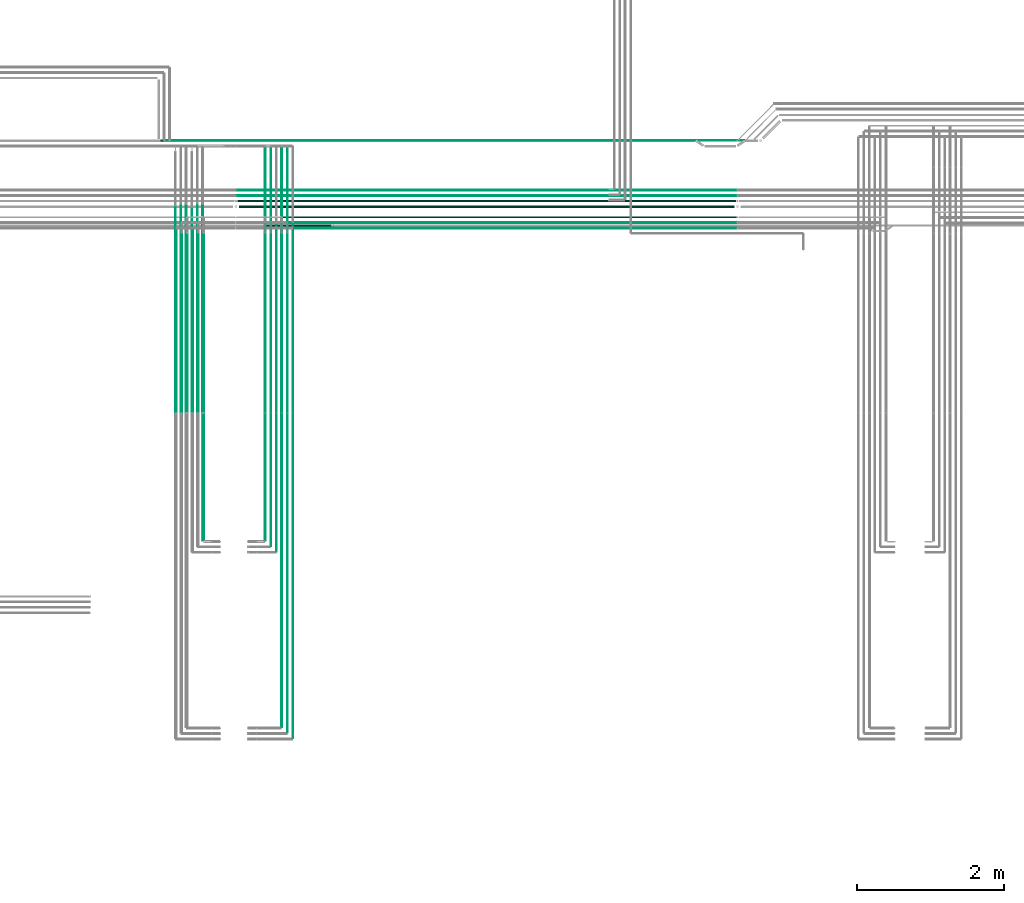
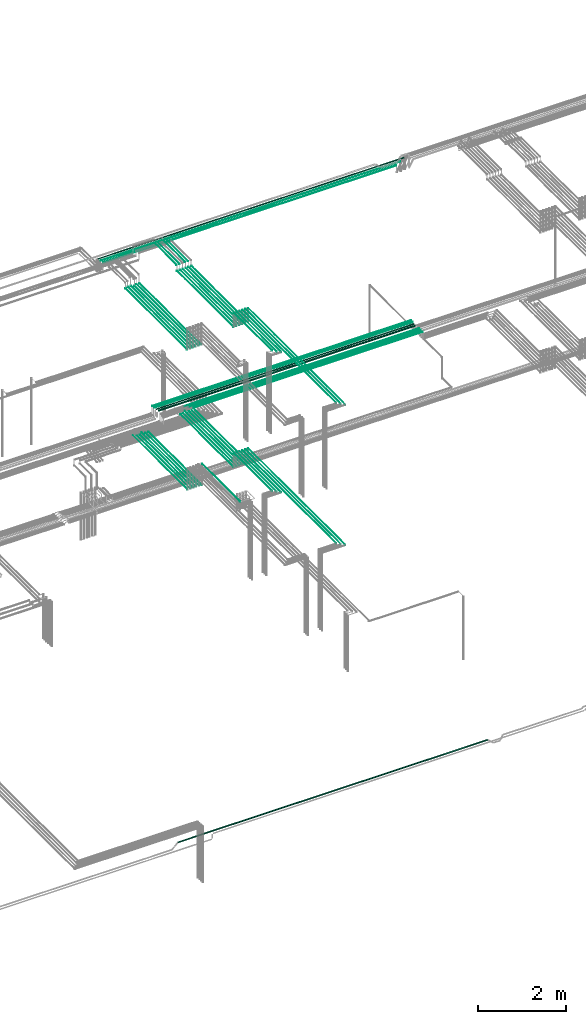
# One storey, part 19 of 331: 52 flow segments.
"""IFC2X3 building model written with IfcOpenShell, lengths in millimetres."""

from ifc_helpers import new_model, entity, si_unit, converted_unit, derived_unit, direction, frame, frame_2d, origin, origin_2d_with_axis, place, context, subcontext, project, spatial, circle, extrude, type_object, element, save


model = new_model("IFC2X3")

# Units and contexts
model_context = context("Model", 3, precision=0.01, world=origin(), true_north=direction((6.12303176911189e-17, 1.0)))
body_context = subcontext(model_context, "Body", "Model", "MODEL_VIEW")
ifc_project = project(units=[si_unit("LENGTHUNIT", "METRE", prefix="MILLI"), si_unit("AREAUNIT", "SQUARE_METRE"), si_unit("VOLUMEUNIT", "CUBIC_METRE"), converted_unit("PLANEANGLEUNIT", "DEGREE", entity("IfcRatioMeasure", 0.0174532925199433), si_unit("PLANEANGLEUNIT", "RADIAN"), dimensions=[0, 0, 0, 0, 0, 0, 0]), si_unit("MASSUNIT", "GRAM", prefix="KILO"), derived_unit("MASSDENSITYUNIT", [(si_unit("MASSUNIT", "GRAM", prefix="KILO"), 1), (si_unit("LENGTHUNIT", "METRE"), -3)]), derived_unit("MOMENTOFINERTIAUNIT", [(si_unit("LENGTHUNIT", "METRE"), 4)]), si_unit("TIMEUNIT", "SECOND"), si_unit("FREQUENCYUNIT", "HERTZ"), si_unit("THERMODYNAMICTEMPERATUREUNIT", "DEGREE_CELSIUS"), derived_unit("THERMALTRANSMITTANCEUNIT", [(si_unit("MASSUNIT", "GRAM", prefix="KILO"), 1), (si_unit("THERMODYNAMICTEMPERATUREUNIT", "KELVIN"), -1), (si_unit("TIMEUNIT", "SECOND"), -3)]), derived_unit("VOLUMETRICFLOWRATEUNIT", [(si_unit("LENGTHUNIT", "METRE"), 3), (si_unit("TIMEUNIT", "SECOND"), -1)]), derived_unit("MASSFLOWRATEUNIT", [(si_unit("MASSUNIT", "GRAM", prefix="KILO"), 1), (si_unit("TIMEUNIT", "SECOND"), -1)]), derived_unit("ROTATIONALFREQUENCYUNIT", [(si_unit("TIMEUNIT", "SECOND"), -1)]), si_unit("ELECTRICCURRENTUNIT", "AMPERE"), si_unit("ELECTRICVOLTAGEUNIT", "VOLT"), si_unit("POWERUNIT", "WATT"), si_unit("FORCEUNIT", "NEWTON", prefix="KILO"), si_unit("ILLUMINANCEUNIT", "LUX"), si_unit("LUMINOUSFLUXUNIT", "LUMEN"), si_unit("LUMINOUSINTENSITYUNIT", "CANDELA"), derived_unit("USERDEFINED", [(si_unit("MASSUNIT", "GRAM", prefix="KILO"), -1), (si_unit("LENGTHUNIT", "METRE"), -2), (si_unit("TIMEUNIT", "SECOND"), 3), (si_unit("LUMINOUSFLUXUNIT", "LUMEN"), 1)]), derived_unit("LINEARVELOCITYUNIT", [(si_unit("LENGTHUNIT", "METRE"), 1), (si_unit("TIMEUNIT", "SECOND"), -1)]), si_unit("PRESSUREUNIT", "PASCAL"), derived_unit("USERDEFINED", [(si_unit("LENGTHUNIT", "METRE"), -2), (si_unit("MASSUNIT", "GRAM", prefix="KILO"), 1), (si_unit("TIMEUNIT", "SECOND"), -2)]), derived_unit("LINEARFORCEUNIT", [(si_unit("MASSUNIT", "GRAM", prefix="KILO"), 1), (si_unit("LENGTHUNIT", "METRE"), 1), (si_unit("TIMEUNIT", "SECOND"), -2), (si_unit("LENGTHUNIT", "METRE"), -1)]), derived_unit("PLANARFORCEUNIT", [(si_unit("MASSUNIT", "GRAM", prefix="KILO"), 1), (si_unit("LENGTHUNIT", "METRE"), 1), (si_unit("TIMEUNIT", "SECOND"), -2), (si_unit("LENGTHUNIT", "METRE"), -2)])], contexts=[model_context])

# Site, building, storey
site_placement = place(None, frame((0.0, -0.00077364408347762, 0.0)))
site = spatial("IfcSite", under=ifc_project, at=site_placement, CompositionType="ELEMENT")
building_placement = place(site_placement, origin())
building = spatial("IfcBuilding", under=site, at=building_placement, CompositionType="ELEMENT")
storey_placement = place(building_placement, origin())
storey = spatial("IfcBuildingStorey", under=building, at=storey_placement, CompositionType="ELEMENT", Elevation=0.0)

# Flow segments
pipe_segment_type = type_object("IfcPipeSegmentType", PredefinedType="NOTDEFINED")
for number, where in (
    (1, (35540.5130615671, 5653.62056382741, 14744.4047277641)),
    (2, (35765.5130615671, 5653.62056382741, 14744.4047277641)),
):
    element("IfcFlowSegment", number, at=place(storey_placement, frame(where)), inside=storey, type_object=pipe_segment_type, context=body_context, shape_type="SweptSolid", body=[
        extrude(circle(Radius=4.0, at=origin_2d_with_axis()), frame((5.59527223591499, 0.0, 5.59527223591499), z_axis=(0.0, 1.0, 0.0), x_axis=(-1.0, 0.0, 0.0)), (0.0, 0.0, 1.0), 2489.38938002189),
    ])
flow_segment_1_placement = place(storey_placement, frame((35465.5130615671, 5653.62056382741, 14744.4047277641)))
element("IfcFlowSegment", 3, at=flow_segment_1_placement, inside=storey, type_object=pipe_segment_type, context=body_context, shape_type="SweptSolid", body=[
    extrude(circle(Radius=4.0, at=origin_2d_with_axis()), frame((5.59527223591499, 0.0, 5.59527223591499), z_axis=(0.0, 1.0, 0.0), x_axis=(-1.0, 0.0, 0.0)), (0.0, 0.0, 1.0), 2426.52868594872),
])
flow_segment_2_placement = place(storey_placement, frame((35690.5130615671, 5653.62056382741, 14744.4047277641)))
element("IfcFlowSegment", 4, at=flow_segment_2_placement, inside=storey, type_object=pipe_segment_type, context=body_context, shape_type="SweptSolid", body=[
    extrude(circle(Radius=4.0, at=origin_2d_with_axis()), frame((5.59527223591499, 0.0, 5.59527223591499), z_axis=(0.0, 1.0, 0.0), x_axis=(-1.0, 0.0, 0.0)), (0.0, 0.0, 1.0), 2426.52868594873),
])
flow_segment_3_placement = place(storey_placement, frame((35388.5130615671, 5657.62056382741, 14742.4047277641)))
element("IfcFlowSegment", 5, at=flow_segment_3_placement, inside=storey, type_object=pipe_segment_type, context=body_context, shape_type="SweptSolid", body=[
    extrude(circle(Radius=6.0, at=frame_2d((8.66293703438714e-12, 0.0), x_axis=(1.0, 0.0))), frame((7.5952722359232, 0.0, 7.5952722359167), z_axis=(0.0, 1.0, 0.0), x_axis=(-1.0, 0.0, 0.0)), (0.0, 0.0, 1.0), 2418.52868594873),
])
flow_segment_4_placement = place(storey_placement, frame((35613.5130615671, 5657.62056382741, 14742.4047277641)))
element("IfcFlowSegment", 6, at=flow_segment_4_placement, inside=storey, type_object=pipe_segment_type, context=body_context, shape_type="SweptSolid", body=[
    extrude(circle(Radius=6.0, at=origin_2d_with_axis()), frame((7.59527223591454, 0.0, 7.5952722359167), z_axis=(0.0, 1.0, 0.0), x_axis=(-1.0, 0.0, 0.0)), (0.0, 0.0, 1.0), 2418.52868594872),
])
flow_segment_5_placement = place(storey_placement, frame((35613.5130615671, 1365.48876707914, 15142.4047277641)))
element("IfcFlowSegment", 7, at=flow_segment_5_placement, inside=storey, type_object=pipe_segment_type, context=body_context, shape_type="SweptSolid", body=[
    extrude(circle(Radius=6.0, at=frame_2d((0.0, 2.16573425859679e-12), x_axis=(1.0, 0.0))), frame((7.59527223591454, 0.0, 7.59527223591887), z_axis=(0.0, 1.0, 0.0), x_axis=(1.0, 0.0, 0.0)), (0.0, 0.0, 1.0), 4264.13179674827),
])
flow_segment_6_placement = place(storey_placement, frame((35388.5130615671, 3905.48876707929, 15142.4047277641)))
element("IfcFlowSegment", 8, at=flow_segment_6_placement, inside=storey, type_object=pipe_segment_type, context=body_context, shape_type="SweptSolid", body=[
    extrude(circle(Radius=6.0, at=frame_2d((0.0, 2.16573425859679e-12), x_axis=(1.0, 0.0))), frame((7.59527223591454, 0.0, 7.59527223591887), z_axis=(0.0, 1.0, 0.0), x_axis=(1.0, 0.0, 0.0)), (0.0, 0.0, 1.0), 1724.13179674812),
])
flow_segment_7_placement = place(storey_placement, frame((35690.5130615671, 1286.48876707975, 15144.4047277641)))
element("IfcFlowSegment", 9, at=flow_segment_7_placement, inside=storey, type_object=pipe_segment_type, context=body_context, shape_type="SweptSolid", body=[
    extrude(circle(Radius=4.0, at=origin_2d_with_axis()), frame((5.59527223591499, 0.0, 5.59527223591499), z_axis=(0.0, 1.0, 0.0), x_axis=(1.0, 0.0, 0.0)), (0.0, 0.0, 1.0), 4347.13179674766),
])
flow_segment_8_placement = place(storey_placement, frame((35765.5130615671, 1211.4887670793, 15144.4047277641)))
element("IfcFlowSegment", 10, at=flow_segment_8_placement, inside=storey, type_object=pipe_segment_type, context=body_context, shape_type="SweptSolid", body=[
    extrude(circle(Radius=4.0, at=origin_2d_with_axis()), frame((5.59527223591499, 0.0, 5.59527223591499), z_axis=(0.0, 1.0, 0.0), x_axis=(1.0, 0.0, 0.0)), (0.0, 0.0, 1.0), 4422.13179674811),
])
flow_segment_9_placement = place(storey_placement, frame((35465.5130615671, 3826.48876707975, 15144.4047277641)))
element("IfcFlowSegment", 11, at=flow_segment_9_placement, inside=storey, type_object=pipe_segment_type, context=body_context, shape_type="SweptSolid", body=[
    extrude(circle(Radius=4.0, at=origin_2d_with_axis()), frame((5.59527223591499, 0.0, 5.59527223591499), z_axis=(0.0, 1.0, 0.0), x_axis=(1.0, 0.0, 0.0)), (0.0, 0.0, 1.0), 1807.13179674766),
])
flow_segment_10_placement = place(storey_placement, frame((35540.5130615671, 3751.48876707903, 15144.4047277641)))
element("IfcFlowSegment", 12, at=flow_segment_10_placement, inside=storey, type_object=pipe_segment_type, context=body_context, shape_type="SweptSolid", body=[
    extrude(circle(Radius=4.0, at=origin_2d_with_axis()), frame((5.59527223591499, 0.0, 5.59527223591499), z_axis=(0.0, 1.0, 0.0), x_axis=(1.0, 0.0, 0.0)), (0.0, 0.0, 1.0), 1882.13179674838),
])
flow_segment_11_placement = place(storey_placement, frame((34403.5132627125, 5653.62056382741, 14544.4047277641)))
element("IfcFlowSegment", 13, at=flow_segment_11_placement, inside=storey, type_object=pipe_segment_type, context=body_context, shape_type="SweptSolid", body=[
    extrude(circle(Radius=4.0, at=frame_2d((-1.29944055515807e-11, 0.0), x_axis=(1.0, 0.0))), frame((5.59527223592365, 0.0, 5.59527223591499), z_axis=(0.0, 1.0, 0.0), x_axis=(-1.0, 0.0, 0.0)), (0.0, 0.0, 1.0), 2489.38938002187),
])
flow_segment_12_placement = place(storey_placement, frame((34178.5132627125, 5653.62056382741, 14544.4047277641)))
element("IfcFlowSegment", 14, at=flow_segment_12_placement, inside=storey, type_object=pipe_segment_type, context=body_context, shape_type="SweptSolid", body=[
    extrude(circle(Radius=4.0, at=frame_2d((-4.33146851719357e-12, 0.0), x_axis=(1.0, 0.0))), frame((5.59527223592365, 0.0, 5.59527223591499), z_axis=(0.0, 1.0, 0.0), x_axis=(-1.0, 0.0, 0.0)), (0.0, 0.0, 1.0), 2489.38938002186),
])
flow_segment_13_placement = place(storey_placement, frame((34478.5132627125, 5653.62056382741, 14544.4047277641)))
element("IfcFlowSegment", 15, at=flow_segment_13_placement, inside=storey, type_object=pipe_segment_type, context=body_context, shape_type="SweptSolid", body=[
    extrude(circle(Radius=4.0, at=origin_2d_with_axis()), frame((5.59527223591499, 0.0, 5.59527223591499), z_axis=(0.0, 1.0, 0.0), x_axis=(-1.0, 0.0, 0.0)), (0.0, 0.0, 1.0), 2426.52868594871),
])
flow_segment_14_placement = place(storey_placement, frame((34253.5132627125, 5653.62056382741, 14544.4047277641)))
element("IfcFlowSegment", 16, at=flow_segment_14_placement, inside=storey, type_object=pipe_segment_type, context=body_context, shape_type="SweptSolid", body=[
    extrude(circle(Radius=4.0, at=origin_2d_with_axis()), frame((5.59527223591499, 0.0, 5.59527223591499), z_axis=(0.0, 1.0, 0.0), x_axis=(-1.0, 0.0, 0.0)), (0.0, 0.0, 1.0), 2426.52868594872),
])
flow_segment_15_placement = place(storey_placement, frame((34551.5132627125, 5657.62056382741, 14542.4047277641)))
element("IfcFlowSegment", 17, at=flow_segment_15_placement, inside=storey, type_object=pipe_segment_type, context=body_context, shape_type="SweptSolid", body=[
    extrude(circle(Radius=6.0, at=frame_2d((-8.66293703438714e-12, -2.16573425859679e-12), x_axis=(1.0, 0.0))), frame((7.5952722359232, 0.0, 7.59527223591887), z_axis=(0.0, 1.0, 0.0), x_axis=(-1.0, 0.0, 0.0)), (0.0, 0.0, 1.0), 2418.52868594873),
])
flow_segment_16_placement = place(storey_placement, frame((34326.5132627125, 5657.62056382741, 14542.4047277641)))
element("IfcFlowSegment", 18, at=flow_segment_16_placement, inside=storey, type_object=pipe_segment_type, context=body_context, shape_type="SweptSolid", body=[
    extrude(circle(Radius=6.0, at=origin_2d_with_axis()), frame((7.59527223591454, 0.0, 7.5952722359167), z_axis=(0.0, 1.0, 0.0), x_axis=(-1.0, 0.0, 0.0)), (0.0, 0.0, 1.0), 2418.52868594872),
])
flow_segment_17_placement = place(storey_placement, frame((34551.5132627125, 3905.48876707931, 15142.4047277641)))
element("IfcFlowSegment", 19, at=flow_segment_17_placement, inside=storey, type_object=pipe_segment_type, context=body_context, shape_type="SweptSolid", body=[
    extrude(circle(Radius=6.0, at=frame_2d((0.0, 2.16573425859679e-12), x_axis=(1.0, 0.0))), frame((7.59527223591454, 0.0, 7.59527223591887), z_axis=(0.0, 1.0, 0.0), x_axis=(1.0, 0.0, 0.0)), (0.0, 0.0, 1.0), 1724.1317967481),
])
flow_segment_18_placement = place(storey_placement, frame((35778.108333803, 8148.41467161336, 14742.4047277641)))
element("IfcFlowSegment", 20, at=flow_segment_18_placement, inside=storey, type_object=pipe_segment_type, context=body_context, shape_type="SweptSolid", body=[
    extrude(circle(Radius=6.0, at=frame_2d((0.0, 2.16573425859679e-12), x_axis=(1.0, 0.0))), frame((0.0, 7.59527223593403, 7.59527223591887), z_axis=(1.0, 0.0, 0.0), x_axis=(0.0, -1.0, 0.0)), (0.0, 0.0, 1.0), 6029.07227010458),
])
flow_segment_19_placement = place(storey_placement, frame((35703.1083377242, 8223.41467161339, 14742.4047277641)))
element("IfcFlowSegment", 21, at=flow_segment_19_placement, inside=storey, type_object=pipe_segment_type, context=body_context, shape_type="SweptSolid", body=[
    extrude(circle(Radius=6.0, at=frame_2d((-1.08286712929839e-12, -2.16573425859679e-12), x_axis=(1.0, 0.0))), frame((0.0, 7.59527223593403, 7.59527223591454), z_axis=(1.0, 0.0, 0.0), x_axis=(0.0, -1.0, 0.0)), (0.0, 0.0, 1.0), 6104.07226741911),
])
flow_segment_20_placement = place(storey_placement, frame((35629.1083191253, 8296.91467161339, 14740.9047401324)))
element("IfcFlowSegment", 22, at=flow_segment_20_placement, inside=storey, type_object=pipe_segment_type, context=body_context, shape_type="SweptSolid", body=[
    extrude(circle(Radius=7.5, at=origin_2d_with_axis()), frame((0.0, 9.09527223593585, 9.09527223591636), z_axis=(1.0, 0.0, 0.0), x_axis=(0.0, -1.0, 0.0)), (0.0, 0.0, 1.0), 6174.07228788098),
])
flow_segment_21_placement = place(storey_placement, frame((35010.080551462, 8668.02529159146, 14742.4047277641)))
element("IfcFlowSegment", 23, at=flow_segment_21_placement, inside=storey, type_object=pipe_segment_type, context=body_context, shape_type="SweptSolid", body=[
    extrude(circle(Radius=6.0, at=frame_2d((-8.66293703438714e-12, 2.16573425859679e-12), x_axis=(1.0, 0.0))), frame((0.0, 7.59527223592428, 7.59527223591454), z_axis=(1.0, 0.0, 0.0), x_axis=(0.0, 1.0, 0.0)), (0.0, 0.0, 1.0), 6797.10005244561),
])
flow_segment_22_placement = place(storey_placement, frame((35010.080551462, 8593.02529159146, 14742.4047277641)))
element("IfcFlowSegment", 24, at=flow_segment_22_placement, inside=storey, type_object=pipe_segment_type, context=body_context, shape_type="SweptSolid", body=[
    extrude(circle(Radius=6.0, at=frame_2d((-8.66293703438714e-12, 0.0), x_axis=(1.0, 0.0))), frame((0.0, 7.59527223592428, 7.5952722359167), z_axis=(1.0, 0.0, 0.0), x_axis=(0.0, 1.0, 0.0)), (0.0, 0.0, 1.0), 6797.1000524456),
])
flow_segment_23_placement = place(storey_placement, frame((35020.080551462, 8513.02529159144, 14737.4047277641)))
element("IfcFlowSegment", 25, at=flow_segment_23_placement, inside=storey, type_object=pipe_segment_type, context=body_context, shape_type="SweptSolid", body=[
    extrude(circle(Radius=11.0, at=frame_2d((0.0, -2.16573425859679e-12), x_axis=(1.0, 0.0))), frame((0.0, 12.5952722359329, 12.5952722359134), z_axis=(1.0, 0.0, 0.0), x_axis=(0.0, -1.0, 0.0)), (0.0, 0.0, 1.0), 6777.1000524456),
])
flow_segment_24_placement = place(storey_placement, frame((35036.080551462, 8431.52529159142, 14730.9047277638)))
element("IfcFlowSegment", 26, at=flow_segment_24_placement, inside=storey, type_object=pipe_segment_type, context=body_context, shape_type="SweptSolid", body=[
    extrude(circle(Radius=17.5, at=origin_2d_with_axis()), frame((0.0, 19.0952722359336, 19.0952722359163), z_axis=(1.0, 0.0, 0.0), x_axis=(0.0, -1.0, 0.0)), (0.0, 0.0, 1.0), 6745.10005244563),
])
flow_segment_25_placement = place(storey_placement, frame((34110.0511495452, 9342.40472776411, 18642.4047277641)))
element("IfcFlowSegment", 27, at=flow_segment_25_placement, inside=storey, type_object=pipe_segment_type, context=body_context, shape_type="SweptSolid", body=[
    extrude(circle(Radius=6.0, at=frame_2d((3.35688810082502e-11, 0.0), x_axis=(1.0, 0.0))), frame((0.0, 7.59527223594919, 7.5952722359167), z_axis=(1.0, 0.0, 0.0), x_axis=(0.0, 1.0, 0.0)), (0.0, 0.0, 1.0), 7696.04795075196),
])
flow_segment_26_placement = place(storey_placement, frame((34390.4558773093, 5653.62056382734, 18444.4047277641)))
element("IfcFlowSegment", 28, at=flow_segment_26_placement, inside=storey, type_object=pipe_segment_type, context=body_context, shape_type="SweptSolid", body=[
    extrude(circle(Radius=4.0, at=frame_2d((-4.33146851719357e-12, 0.0), x_axis=(1.0, 0.0))), frame((5.59527223591499, 0.0, 5.59527223591499), z_axis=(0.0, 1.0, 0.0), x_axis=(-1.0, 0.0, 0.0)), (0.0, 0.0, 1.0), 2777.21564201884),
])
flow_segment_27_placement = place(storey_placement, frame((34165.4558773093, 5653.62056382734, 18444.4047277641)))
element("IfcFlowSegment", 29, at=flow_segment_27_placement, inside=storey, type_object=pipe_segment_type, context=body_context, shape_type="SweptSolid", body=[
    extrude(circle(Radius=4.0, at=origin_2d_with_axis()), frame((5.59527223591499, 0.0, 5.59527223591499), z_axis=(0.0, 1.0, 0.0), x_axis=(1.0, 0.0, 0.0)), (0.0, 0.0, 1.0), 2795.00000000001),
])
for number, where in (
    (30, (34465.4558773093, 5653.62056382735, 18444.4047277641)),
    (31, (34240.4558773093, 5653.62056382735, 18444.4047277641)),
):
    element("IfcFlowSegment", number, at=place(storey_placement, frame(where)), inside=storey, type_object=pipe_segment_type, context=body_context, shape_type="SweptSolid", body=[
        extrude(circle(Radius=4.0, at=origin_2d_with_axis()), frame((5.59527223591499, 0.0, 5.59527223591499), z_axis=(0.0, 1.0, 0.0), x_axis=(-1.0, 0.0, 0.0)), (0.0, 0.0, 1.0), 2821.19017065502),
    ])
flow_segment_28_placement = place(storey_placement, frame((34538.4558773093, 5657.62056382736, 18442.4047277641)))
element("IfcFlowSegment", 32, at=flow_segment_28_placement, inside=storey, type_object=pipe_segment_type, context=body_context, shape_type="SweptSolid", body=[
    extrude(circle(Radius=6.0, at=origin_2d_with_axis()), frame((7.59527223591454, 0.0, 7.5952722359167), z_axis=(0.0, 1.0, 0.0), x_axis=(-1.0, 0.0, 0.0)), (0.0, 0.0, 1.0), 2813.190170655),
])
flow_segment_29_placement = place(storey_placement, frame((34313.4558773093, 5657.62056382735, 18442.4047277641)))
element("IfcFlowSegment", 33, at=flow_segment_29_placement, inside=storey, type_object=pipe_segment_type, context=body_context, shape_type="SweptSolid", body=[
    extrude(circle(Radius=6.0, at=origin_2d_with_axis()), frame((7.59527223591454, 0.0, 7.5952722359167), z_axis=(0.0, 1.0, 0.0), x_axis=(-1.0, 0.0, 0.0)), (0.0, 0.0, 1.0), 2813.19017065502),
])
for number, where in (
    (34, (35540.7427281404, 5653.62056382734, 18644.4047277641)),
    (35, (35765.7427281405, 5653.62056382734, 18644.4047277641)),
):
    element("IfcFlowSegment", number, at=place(storey_placement, frame(where)), inside=storey, type_object=pipe_segment_type, context=body_context, shape_type="SweptSolid", body=[
        extrude(circle(Radius=4.0, at=origin_2d_with_axis()), frame((5.59527223591499, 0.0, 5.59527223591499), z_axis=(0.0, 1.0, 0.0), x_axis=(-1.0, 0.0, 0.0)), (0.0, 0.0, 1.0), 2571.19017065503),
    ])
flow_segment_30_placement = place(storey_placement, frame((35465.7427281404, 8244.81073448236, 18794.4047277641)))
element("IfcFlowSegment", 36, at=flow_segment_30_placement, inside=storey, type_object=pipe_segment_type, context=body_context, shape_type="SweptSolid", body=[
    extrude(circle(Radius=4.0, at=frame_2d((8.66293703438714e-12, 0.0), x_axis=(1.0, 0.0))), frame((5.59527223592365, 0.0, 5.59527223591499), z_axis=(0.0, 1.0, 0.0), x_axis=(-1.0, 0.0, 0.0)), (0.0, 0.0, 1.0), 1020.18926551794),
])
flow_segment_31_placement = place(storey_placement, frame((35465.7427281405, 5653.62056382735, 18644.4047277641)))
element("IfcFlowSegment", 37, at=flow_segment_31_placement, inside=storey, type_object=pipe_segment_type, context=body_context, shape_type="SweptSolid", body=[
    extrude(circle(Radius=4.0, at=origin_2d_with_axis()), frame((5.59527223591499, 0.0, 5.59527223591499), z_axis=(0.0, 1.0, 0.0), x_axis=(-1.0, 0.0, 0.0)), (0.0, 0.0, 1.0), 2571.19017065501),
])
flow_segment_32_placement = place(storey_placement, frame((35690.7427281404, 8244.81073448235, 18794.4047277641)))
element("IfcFlowSegment", 38, at=flow_segment_32_placement, inside=storey, type_object=pipe_segment_type, context=body_context, shape_type="SweptSolid", body=[
    extrude(circle(Radius=4.0, at=frame_2d((8.66293703438714e-12, 0.0), x_axis=(1.0, 0.0))), frame((5.59527223592365, 0.0, 5.59527223591499), z_axis=(0.0, 1.0, 0.0), x_axis=(-1.0, 0.0, 0.0)), (0.0, 0.0, 1.0), 1020.18926551795),
])
flow_segment_33_placement = place(storey_placement, frame((35690.7427281405, 5653.62056382734, 18644.4047277641)))
element("IfcFlowSegment", 39, at=flow_segment_33_placement, inside=storey, type_object=pipe_segment_type, context=body_context, shape_type="SweptSolid", body=[
    extrude(circle(Radius=4.0, at=origin_2d_with_axis()), frame((5.59527223591499, 0.0, 5.59527223591499), z_axis=(0.0, 1.0, 0.0), x_axis=(-1.0, 0.0, 0.0)), (0.0, 0.0, 1.0), 2571.19017065502),
])
flow_segment_34_placement = place(storey_placement, frame((35388.7427281404, 8248.81073448236, 18792.4047277641)))
element("IfcFlowSegment", 40, at=flow_segment_34_placement, inside=storey, type_object=pipe_segment_type, context=body_context, shape_type="SweptSolid", body=[
    extrude(circle(Radius=6.0, at=frame_2d((1.29944055515807e-11, 0.0), x_axis=(1.0, 0.0))), frame((7.59527223592753, 0.0, 7.5952722359167), z_axis=(0.0, 1.0, 0.0), x_axis=(-1.0, 0.0, 0.0)), (0.0, 0.0, 1.0), 1012.18926551777),
])
flow_segment_35_placement = place(storey_placement, frame((35388.7427281405, 5657.62056382736, 18642.4047277641)))
element("IfcFlowSegment", 41, at=flow_segment_35_placement, inside=storey, type_object=pipe_segment_type, context=body_context, shape_type="SweptSolid", body=[
    extrude(circle(Radius=6.0, at=frame_2d((0.0, -2.16573425859679e-12), x_axis=(1.0, 0.0))), frame((7.59527223591454, 0.0, 7.59527223591887), z_axis=(0.0, 1.0, 0.0), x_axis=(-1.0, 0.0, 0.0)), (0.0, 0.0, 1.0), 2563.19017065501),
])
flow_segment_36_placement = place(storey_placement, frame((35613.7427281404, 8248.81073448235, 18792.4047277641)))
element("IfcFlowSegment", 42, at=flow_segment_36_placement, inside=storey, type_object=pipe_segment_type, context=body_context, shape_type="SweptSolid", body=[
    extrude(circle(Radius=6.0, at=frame_2d((8.66293703438714e-12, 0.0), x_axis=(1.0, 0.0))), frame((7.5952722359232, 0.0, 7.5952722359167), z_axis=(0.0, 1.0, 0.0), x_axis=(-1.0, 0.0, 0.0)), (0.0, 0.0, 1.0), 1012.18926551778),
])
flow_segment_37_placement = place(storey_placement, frame((35613.7427281405, 5657.62056382734, 18642.4047277641)))
element("IfcFlowSegment", 43, at=flow_segment_37_placement, inside=storey, type_object=pipe_segment_type, context=body_context, shape_type="SweptSolid", body=[
    extrude(circle(Radius=6.0, at=frame_2d((0.0, -2.16573425859679e-12), x_axis=(1.0, 0.0))), frame((7.59527223591454, 0.0, 7.59527223591887), z_axis=(0.0, 1.0, 0.0), x_axis=(-1.0, 0.0, 0.0)), (0.0, 0.0, 1.0), 2563.19017065502),
])
flow_segment_38_placement = place(storey_placement, frame((35613.7427281405, 1365.48876707969, 19042.4047277641)))
element("IfcFlowSegment", 44, at=flow_segment_38_placement, inside=storey, type_object=pipe_segment_type, context=body_context, shape_type="SweptSolid", body=[
    extrude(circle(Radius=6.0, at=origin_2d_with_axis()), frame((7.59527223591454, 0.0, 7.5952722359167), z_axis=(0.0, 1.0, 0.0), x_axis=(1.0, 0.0, 0.0)), (0.0, 0.0, 1.0), 4264.13179674766),
])
flow_segment_39_placement = place(storey_placement, frame((35388.7427281405, 3905.4887670797, 19042.4047277641)))
element("IfcFlowSegment", 45, at=flow_segment_39_placement, inside=storey, type_object=pipe_segment_type, context=body_context, shape_type="SweptSolid", body=[
    extrude(circle(Radius=6.0, at=origin_2d_with_axis()), frame((7.59527223591454, 0.0, 7.5952722359167), z_axis=(0.0, 1.0, 0.0), x_axis=(1.0, 0.0, 0.0)), (0.0, 0.0, 1.0), 1724.13179674766),
])
flow_segment_40_placement = place(storey_placement, frame((35690.7427281405, 1286.48876707969, 19044.4047277641)))
element("IfcFlowSegment", 46, at=flow_segment_40_placement, inside=storey, type_object=pipe_segment_type, context=body_context, shape_type="SweptSolid", body=[
    extrude(circle(Radius=4.0, at=origin_2d_with_axis()), frame((5.59527223591499, 0.0, 5.59527223591499), z_axis=(0.0, 1.0, 0.0), x_axis=(1.0, 0.0, 0.0)), (0.0, 0.0, 1.0), 4347.13179674766),
])
flow_segment_41_placement = place(storey_placement, frame((35765.7427281405, 1211.48876707969, 19044.4047277641)))
element("IfcFlowSegment", 47, at=flow_segment_41_placement, inside=storey, type_object=pipe_segment_type, context=body_context, shape_type="SweptSolid", body=[
    extrude(circle(Radius=4.0, at=origin_2d_with_axis()), frame((5.59527223591499, 0.0, 5.59527223591499), z_axis=(0.0, 1.0, 0.0), x_axis=(1.0, 0.0, 0.0)), (0.0, 0.0, 1.0), 4422.13179674766),
])
flow_segment_42_placement = place(storey_placement, frame((35465.7427281405, 3826.48876707969, 19044.4047277641)))
element("IfcFlowSegment", 48, at=flow_segment_42_placement, inside=storey, type_object=pipe_segment_type, context=body_context, shape_type="SweptSolid", body=[
    extrude(circle(Radius=4.0, at=origin_2d_with_axis()), frame((5.59527223591499, 0.0, 5.59527223591499), z_axis=(0.0, 1.0, 0.0), x_axis=(1.0, 0.0, 0.0)), (0.0, 0.0, 1.0), 1807.13179674766),
])
flow_segment_43_placement = place(storey_placement, frame((35540.7427281405, 3751.48876707969, 19044.4047277641)))
element("IfcFlowSegment", 49, at=flow_segment_43_placement, inside=storey, type_object=pipe_segment_type, context=body_context, shape_type="SweptSolid", body=[
    extrude(circle(Radius=4.0, at=origin_2d_with_axis()), frame((5.59527223591499, 0.0, 5.59527223591499), z_axis=(0.0, 1.0, 0.0), x_axis=(1.0, 0.0, 0.0)), (0.0, 0.0, 1.0), 1882.13179674766),
])
flow_segment_44_placement = place(building_placement, frame((34035.0511495452, 9342.40472776403, 18717.4047277642)))
element("IfcFlowSegment", 50, at=flow_segment_44_placement, inside=storey, type_object=pipe_segment_type, context=body_context, shape_type="SweptSolid", body=[
    extrude(circle(Radius=6.0, at=frame_2d((2.26319230023364e-10, 0.0), x_axis=(1.0, 0.0))), frame((0.0, 7.59527223614194, 7.5952722359167), z_axis=(1.0, 0.0, 0.0), x_axis=(0.0, 1.0, 0.0)), (0.0, 0.0, 1.0), 7877.11396792985),
])
flow_segment_45_placement = place(building_placement, frame((33970.0511495452, 9337.40472776403, 18787.4047277641)))
element("IfcFlowSegment", 51, at=flow_segment_45_placement, inside=storey, type_object=pipe_segment_type, context=body_context, shape_type="SweptSolid", body=[
    extrude(circle(Radius=11.0, at=frame_2d((2.23070628635469e-10, -2.16573425859679e-12), x_axis=(1.0, 0.0))), frame((0.0, 12.5952722361397, 12.5952722359177), z_axis=(1.0, 0.0, 0.0), x_axis=(0.0, 1.0, 0.0)), (0.0, 0.0, 1.0), 8038.17998510783),
])
flow_segment_46_placement = place(building_placement, frame((35407.8349909584, 8179.92098945658, 2759.40472776404)))
element("IfcFlowSegment", 52, at=flow_segment_46_placement, inside=storey, type_object=pipe_segment_type, context=body_context, shape_type="SweptSolid", body=[
    extrude(circle(Radius=14.0, at=frame_2d((-1.01789510154049e-10, 0.0), x_axis=(1.0, 0.0))), frame((0.0, 15.5952722360178, 15.595272235916), z_axis=(1.0, 0.0, 0.0), x_axis=(0.0, 1.0, 0.0)), (0.0, 0.0, 1.0), 8128.83818935588),
])

save(model, "model.ifc")
